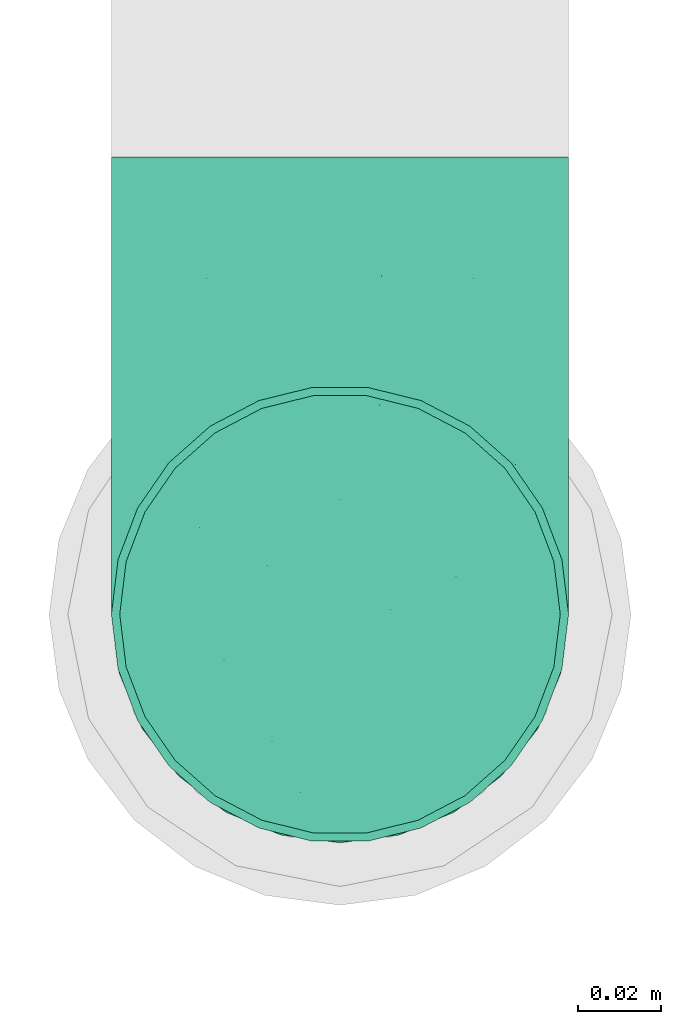
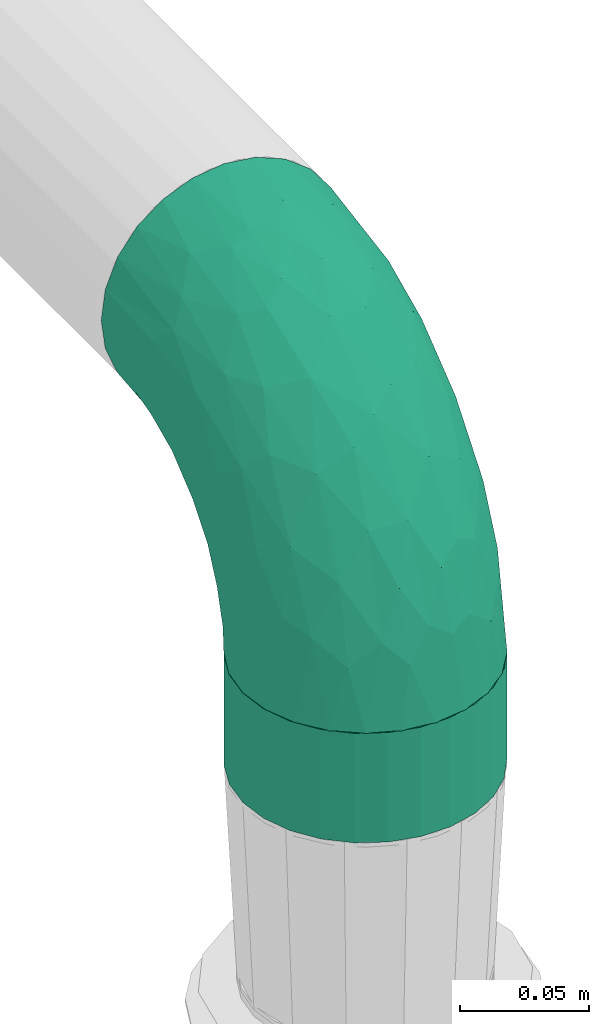
# One storey, part 79 of 115: 1 flow fitting, 1 flow segment.
"""IFC2X3 building model written with IfcOpenShell, lengths in millimetres."""

from ifc_helpers import new_model, entity, si_unit, converted_unit, derived_unit, direction, frame, origin_with_axes, origin_2d_with_axis, place, context, subcontext, project, spatial, hollow_circle, extrude, open_shell, surface_model, source, transform, mapped, material, layer, layer_set, layer_usage, type_object, element, save


model = new_model("IFC2X3")

# Units and contexts
model_context = context("Model", 3, precision=1e-05, world=origin_with_axes(), true_north=direction((0.0, 1.0)))
body_context = subcontext(model_context, "Body", "Model", "MODEL_VIEW")
ifc_project = project(units=[si_unit("AREAUNIT", "SQUARE_METRE"), si_unit("VOLUMEUNIT", "CUBIC_METRE", prefix="DECI"), si_unit("TIMEUNIT", "SECOND"), si_unit("THERMODYNAMICTEMPERATUREUNIT", "DEGREE_CELSIUS"), si_unit("PRESSUREUNIT", "PASCAL"), si_unit("MASSUNIT", "GRAM", prefix="KILO"), si_unit("LENGTHUNIT", "METRE", prefix="MILLI"), si_unit("POWERUNIT", "WATT"), si_unit("ELECTRICCURRENTUNIT", "AMPERE"), si_unit("ELECTRICVOLTAGEUNIT", "VOLT"), derived_unit("VOLUMETRICFLOWRATEUNIT", [(si_unit("VOLUMEUNIT", "CUBIC_METRE", prefix="DECI"), 1), (si_unit("TIMEUNIT", "SECOND"), -1)]), derived_unit("LINEARVELOCITYUNIT", [(si_unit("LENGTHUNIT", "METRE"), 1), (si_unit("TIMEUNIT", "SECOND"), -1)]), derived_unit("MASSDENSITYUNIT", [(si_unit("MASSUNIT", "GRAM", prefix="KILO"), 1), (si_unit("VOLUMEUNIT", "CUBIC_METRE"), -1)]), converted_unit("PLANEANGLEUNIT", "DEGREE", entity("IfcRatioMeasure", 0.01745), si_unit("PLANEANGLEUNIT", "RADIAN"), dimensions=[0, 0, 0, 0, 0, 0, 0])], contexts=[model_context])

# Site, building, storey
site_placement = place(None, origin_with_axes())
site = spatial("IfcSite", under=ifc_project, at=site_placement, CompositionType="ELEMENT")
building_placement = place(site_placement, origin_with_axes())
building = spatial("IfcBuilding", under=site, at=building_placement, Name="mc-building", CompositionType="ELEMENT")
storey_placement = place(building_placement, frame((0.0, 0.0, 2950.0), z_axis=(0.0, 0.0, 1.0), x_axis=(1.0, 0.0, 0.0)))
storey = spatial("IfcBuildingStorey", under=building, at=storey_placement, Name="2. Korrus", CompositionType="ELEMENT", Elevation=2950.0)

# Flow segment
ifc_material = material(Name="FZ1")
ifc_layer = layer(ifc_material, 0.0)
ifc_layer_set = layer_set([ifc_layer], Name="FZ1")
ifc_layer_usage = layer_usage(ifc_layer_set, "AXIS1", "POSITIVE", 0.0)
duct_segment_type = type_object("IfcDuctSegmentType", PredefinedType="RIGIDSEGMENT")
shared_shape_1 = source(origin_with_axes(), body_context, "Body", "SweptSolid", [
    extrude(hollow_circle(Radius=55.0, WallThickness=2.0, at=origin_2d_with_axis()), frame((0.0, 0.0, 0.0), z_axis=(1.0, 0.0, 0.0), x_axis=(0.0, 1.0, 0.0)), (0.0, 0.0, 1.0), 51.9),
])
flow_segment_placement = place(storey_placement, frame((18604.54349, 8183.57591, 2355.0), z_axis=(0.0, 1.0, 0.0), x_axis=(0.0, 0.0, -1.0)))
element("IfcFlowSegment", 1, at=flow_segment_placement, inside=storey, type_object=duct_segment_type, material=ifc_layer_usage, context=body_context, shape_type="MappedRepresentation", body=[
    mapped(shared_shape_1, transform((0.0, 0.0, 0.0), scale=1.0)),
])

# Flow fitting
duct_fitting_type = type_object("IfcDuctFittingType", Name="BU", PredefinedType="BEND")
shared_shape_2 = source(origin_with_axes(), body_context, "Body", "SurfaceModel", [
    surface_model("IfcShellBasedSurfaceModel", [(-110.0, -38.89087, -38.89087), (-110.0, -55.0, 0.0), (-110.0, -27.5, -47.63139), (-110.0, -53.12592, -14.23505), (-110.0, -47.63139, -27.5), (-110.0, 47.63139, -27.5), (-110.0, 53.12592, 14.23505), (-110.0, 53.12592, -14.23505), (-110.0, -14.23505, -53.12592), (-110.0, 0.0, -55.0), (-110.0, 38.89087, -38.89087), (-110.0, 27.5, -47.63139), (-110.0, 14.23505, -53.12592), (-110.0, 55.0, 0.0), (-110.0, -53.12592, 14.23505), (-110.0, -47.63139, 27.5), (-110.0, -38.89087, 38.89087), (-110.0, 0.0, 55.0), (-110.0, -27.5, 47.63139), (-110.0, -14.23505, 53.12592), (-110.0, 38.89087, 38.89087), (-110.0, 47.63139, 27.5), (-110.0, 27.5, 47.63139), (-110.0, 14.23505, 53.12592), (0.0, -110.0, -55.0), (14.23505, -110.0, -53.12592), (-14.23505, -110.0, -53.12592), (-53.12592, -110.0, 14.23505), (-27.5, -110.0, -47.63139), (-47.63139, -110.0, -27.5), (-38.89087, -110.0, -38.89087), (55.0, -110.0, 0.0), (53.12592, -110.0, 14.23505), (38.89087, -110.0, -38.89087), (27.5, -110.0, -47.63139), (53.12592, -110.0, -14.23505), (47.63139, -110.0, -27.5), (-53.12592, -110.0, -14.23505), (-47.63139, -110.0, 27.5), (-38.89087, -110.0, 38.89087), (14.23505, -110.0, 53.12592), (-27.5, -110.0, 47.63139), (-14.23505, -110.0, 53.12592), (47.63139, -110.0, 27.5), (38.89087, -110.0, 38.89087), (27.5, -110.0, 47.63139), (0.0, -110.0, 55.0), (-55.0, -110.0, 0.0), (-60.44912, -32.56953, 51.94617), (-76.6405, -38.18013, 45.55988), (-64.21732, -48.68956, 43.63444), (-90.15553, -11.94394, 54.09138), (-76.00813, -5.38378, 55.0), (-70.18771, -18.55163, 54.03432), (-78.5998, -26.77405, 50.81338), (-93.27622, -45.77614, 33.48188), (-75.55424, -54.2118, 32.41257), (-96.12334, -22.13664, 50.81337), (-32.04182, -59.64019, 52.24446), (-18.36258, -70.48427, 54.04484), (-21.00813, -45.34362, 55.0), (-63.60674, -66.07878, 29.97482), (-74.66383, -63.08407, 19.92123), (-63.88653, -74.77858, 17.99134), (-93.11138, -56.59448, 10.50359), (-99.597, -52.72185, 18.52927), (-98.21577, -57.34403, 0.0), (-53.42855, -92.60092, 21.04759), (-88.54852, -54.8376, 21.04759), (-5.38378, -76.00813, 55.0), (-11.86161, -90.23965, 54.10313), (-56.64619, -93.12774, 10.22088), (-57.34403, -98.21577, 0.0), (-44.60838, -44.60838, 52.13415), (-45.34362, -21.00813, 55.0), (-92.68484, -35.46673, 43.63443), (-22.25266, -95.40765, 50.81337), (-27.23711, -77.39884, 50.81337), (-43.70931, -69.58671, 44.47149), (-35.97783, -90.61597, 43.63443), (-58.67786, -84.31125, 16.04456), (-57.2828, -79.3123, 24.9774), (-82.93277, -60.36161, 12.91784), (-49.88337, -54.51816, 47.224), (-74.57753, -66.83759, 9.55742), (-45.35812, -94.97281, 33.48188), (-59.18663, -88.95241, 0.0), (-51.517, -78.6292, 33.48188), (-65.14788, -80.03077, 0.0), (-56.45322, -62.06476, 39.63545), (-88.95241, -59.18663, 0.0), (-80.03077, -65.14788, 0.0), (-71.10913, -71.10913, 0.0), (-94.9309, -45.36788, -33.48188), (-93.11358, -56.60141, -10.46614), (-99.64997, -52.79499, -18.30015), (-79.99933, -46.56772, -37.92748), (-90.20425, -36.08686, -43.63443), (-45.34362, -21.00813, -55.0), (-72.75364, -19.68651, -53.60527), (-76.00813, -5.38378, -55.0), (-21.00813, -45.34362, -55.0), (-5.38378, -76.00813, -55.0), (-21.91957, -65.12078, -53.85897), (-35.41876, -92.89265, -43.63443), (-91.10309, -11.02766, -54.21832), (-45.77614, -93.27622, -33.48188), (-90.50474, -23.21022, -50.81337), (-70.92854, -33.31794, -49.51754), (-78.52933, -63.35627, -11.73997), (-24.91508, -84.05606, -50.81337), (-88.78941, -54.74452, -21.04759), (-63.49062, -67.59111, -28.46929), (-73.36422, -62.46673, -22.94182), (-69.59921, -57.34866, -33.48187), (-56.59448, -93.11138, -10.50359), (-54.10679, -75.85581, -32.31867), (-54.8376, -88.54852, -21.04759), (-57.75956, -31.09612, -52.80882), (-52.72185, -99.597, -18.52927), (-12.62913, -89.46304, -53.99097), (-34.46825, -66.46123, -50.04329), (-43.9837, -43.9837, -52.42279), (-65.78527, -72.58348, -17.68796), (-57.47001, -51.99467, -44.91465), (-70.34468, -43.65295, -44.21951), (-60.72547, -82.29174, -12.88567), (-42.34915, -74.24548, -43.63444), (-57.25194, -63.5016, -38.08211), (-80.95344, -53.56991, -29.32027), (-52.32891, -4.55257, -54.0482), (14.95561, -36.05775, -42.26543), (14.88266, -20.92917, -33.7947), (32.52942, -47.13398, -30.48571), (19.3559, -65.35825, -48.00507), (30.24048, -70.09027, -41.7461), (-28.49299, 30.5778, -16.4009), (-47.13398, 32.52942, -30.48571), (-70.35075, 46.44478, -19.5952), (-22.4954, -22.4954, -53.25347), (-4.55257, -52.32891, -54.0482), (-75.47368, 11.22546, -52.60718), (-81.32209, 51.5606, -9.98467), (-70.09027, 30.24048, -41.7461), (-80.81763, 41.84862, -32.14655), (-9.15831, 10.852, -27.8997), (-36.05774, 14.95561, -42.26543), (-65.35825, 19.3559, -48.00507), (3.94376, -43.9333, -50.53315), (11.22546, -75.47368, -52.60718), (-43.9333, 3.94376, -50.53315), (-13.39742, -13.39743, -48.13058), (50.20582, -74.51695, -9.9731), (41.8609, -47.82256, -9.92641), (49.37776, -67.29486, 0.0), (18.93131, -11.7156, -17.56239), (-1.23348, 12.25375, -12.18106), (-27.5, 32.89419, 0.0), (41.84862, -80.81763, -32.14655), (46.44478, -70.35075, -19.5952), (35.70604, -41.31408, -20.38235), (6.67262, 6.67262, 0.0), (32.89419, -27.5, 0.0), (-50.36265, 42.95545, -9.51562), (-67.29486, 49.37776, 0.0), (-5.47251, -5.47251, -39.92906), (-70.35075, 46.44478, 19.5952), (-74.51695, 50.20582, 9.9731), (-47.13398, 32.52942, 30.48571), (-41.31407, 35.70604, 20.38235), (-80.81763, 41.84862, 32.14655), (11.22546, -75.47368, 52.60718), (-4.55257, -52.32891, 54.0482), (-36.05774, 14.95561, 42.26543), (-65.35825, 19.3559, 48.00507), (-43.9333, 3.94376, 50.53315), (-70.09027, 30.24048, 41.7461), (-11.7156, 18.93131, 17.56239), (12.25375, -1.23348, 12.18106), (30.5778, -28.49299, 16.4009), (42.95545, -50.36265, 9.51562), (51.5606, -81.32209, 9.98467), (-52.32891, -4.55257, 54.0482), (-75.47368, 11.22546, 52.60718), (-13.39742, -13.39743, 48.13058), (-22.4954, -22.4954, 53.25347), (3.94376, -43.9333, 50.53315), (-20.92916, 14.88266, 33.79469), (10.852, -9.15831, 27.8997), (-47.82256, 41.8609, 9.92641), (32.52942, -47.13398, 30.48571), (46.44478, -70.35075, 19.5952), (41.84862, -80.81763, 32.14655), (14.95561, -36.05775, 42.26543), (19.3559, -65.35825, 48.00507), (30.24048, -70.09027, 41.7461), (-5.47251, -5.47251, 39.92906)], [open_shell([[[0, 1, 2]], [[3, 1, 4]], [[5, 6, 7]], [[8, 1, 9]], [[2, 1, 8]], [[4, 1, 0]], [[10, 9, 6]], [[9, 10, 11]], [[11, 12, 9]], [[6, 5, 10]], [[7, 6, 13]], [[14, 15, 9]], [[9, 15, 16]], [[17, 16, 18]], [[9, 16, 17]], [[19, 17, 18]], [[9, 20, 21]], [[6, 9, 21]], [[9, 22, 20]], [[23, 22, 9]], [[17, 23, 9]], [[9, 1, 14]], [[24, 25, 26]], [[26, 27, 28]], [[29, 30, 27]], [[28, 27, 30]], [[26, 31, 32]], [[33, 31, 34]], [[25, 34, 31]], [[35, 31, 36]], [[33, 36, 31]], [[31, 26, 25]], [[29, 27, 37]], [[38, 27, 26]], [[39, 38, 26]], [[40, 41, 26]], [[41, 39, 26]], [[40, 42, 41]], [[43, 44, 26]], [[43, 26, 32]], [[44, 45, 26]], [[26, 45, 40]], [[40, 46, 42]], [[47, 37, 27]], [[48, 49, 50]], [[51, 52, 17]], [[48, 53, 54]], [[49, 55, 56]], [[16, 15, 55]], [[18, 57, 19]], [[58, 59, 60]], [[61, 62, 63]], [[64, 65, 14]], [[53, 51, 54]], [[66, 64, 14]], [[27, 38, 67]], [[65, 68, 55]], [[68, 65, 64]], [[69, 59, 70]], [[71, 72, 27]], [[73, 60, 74]], [[55, 49, 75]], [[42, 70, 76]], [[51, 57, 54]], [[77, 78, 79]], [[42, 76, 41]], [[46, 70, 42]], [[55, 68, 56]], [[75, 18, 16]], [[77, 79, 76]], [[80, 67, 81]], [[68, 82, 62]], [[83, 78, 58]], [[82, 84, 62]], [[39, 79, 85]], [[71, 67, 80]], [[72, 71, 86]], [[67, 85, 87]], [[88, 80, 63]], [[39, 41, 79]], [[87, 79, 78]], [[55, 75, 16]], [[50, 89, 83]], [[38, 39, 85]], [[56, 68, 62]], [[61, 87, 89]], [[48, 50, 83]], [[18, 75, 57]], [[54, 75, 49]], [[38, 85, 67]], [[85, 79, 87]], [[56, 62, 61]], [[50, 56, 89]], [[87, 61, 81]], [[90, 64, 66]], [[14, 1, 66]], [[91, 92, 84]], [[82, 90, 91]], [[90, 82, 64]], [[62, 84, 63]], [[84, 82, 91]], [[64, 82, 68]], [[65, 15, 14]], [[15, 65, 55]], [[72, 47, 27]], [[86, 71, 80]], [[67, 71, 27]], [[88, 63, 92]], [[63, 80, 81]], [[63, 81, 61]], [[87, 81, 67]], [[41, 76, 79]], [[70, 59, 77]], [[76, 70, 77]], [[69, 70, 46]], [[77, 59, 58]], [[59, 69, 60]], [[77, 58, 78]], [[73, 58, 60]], [[19, 57, 51]], [[54, 57, 75]], [[19, 51, 17]], [[53, 52, 51]], [[53, 74, 52]], [[73, 74, 48]], [[53, 48, 74]], [[83, 73, 48]], [[73, 83, 58]], [[78, 83, 89]], [[78, 89, 87]], [[61, 89, 56]], [[54, 49, 48]], [[50, 49, 56]], [[88, 86, 80]], [[63, 84, 92]], [[93, 4, 0]], [[66, 94, 90]], [[95, 94, 3]], [[96, 93, 97]], [[98, 99, 100]], [[0, 2, 97]], [[101, 102, 103]], [[104, 28, 30]], [[9, 105, 8]], [[30, 106, 104]], [[107, 105, 99]], [[97, 107, 108]], [[94, 109, 90]], [[2, 8, 107]], [[94, 66, 3]], [[110, 26, 28]], [[94, 111, 109]], [[112, 113, 114]], [[72, 115, 37]], [[116, 106, 117]], [[98, 118, 99]], [[119, 115, 117]], [[115, 119, 37]], [[110, 120, 26]], [[103, 110, 121]], [[117, 106, 119]], [[120, 110, 103]], [[98, 101, 122]], [[117, 123, 116]], [[108, 124, 125]], [[126, 117, 115]], [[30, 29, 106]], [[120, 102, 24]], [[110, 104, 127]], [[97, 125, 96]], [[118, 122, 124]], [[124, 127, 128]], [[93, 0, 97]], [[86, 126, 115]], [[127, 106, 116]], [[129, 113, 111]], [[4, 93, 95]], [[114, 129, 96]], [[28, 104, 110]], [[127, 104, 106]], [[2, 107, 97]], [[108, 107, 99]], [[118, 108, 99]], [[100, 99, 105]], [[128, 112, 114]], [[127, 124, 121]], [[66, 1, 3]], [[91, 90, 109]], [[95, 111, 94]], [[109, 123, 92]], [[114, 113, 129]], [[111, 95, 93]], [[95, 3, 4]], [[86, 115, 72]], [[37, 47, 72]], [[88, 92, 123]], [[123, 117, 126]], [[126, 88, 123]], [[88, 126, 86]], [[119, 29, 37]], [[29, 119, 106]], [[111, 93, 129]], [[124, 114, 125]], [[100, 105, 9]], [[8, 105, 107]], [[108, 118, 124]], [[122, 118, 98]], [[96, 129, 93]], [[109, 111, 113]], [[113, 123, 109]], [[116, 123, 112]], [[113, 112, 123]], [[116, 112, 128]], [[116, 128, 127]], [[124, 128, 114]], [[103, 122, 101]], [[127, 121, 110]], [[121, 122, 103]], [[122, 121, 124]], [[26, 120, 24]], [[102, 120, 103]], [[108, 125, 97]], [[109, 92, 91]], [[96, 125, 114]], [[100, 130, 98]], [[131, 132, 133]], [[134, 135, 34]], [[136, 137, 138]], [[101, 139, 140]], [[9, 141, 100]], [[138, 7, 142]], [[137, 143, 144]], [[142, 7, 13]], [[145, 146, 137]], [[146, 147, 143]], [[5, 138, 144]], [[7, 138, 5]], [[5, 144, 10]], [[140, 148, 149]], [[143, 11, 10]], [[147, 12, 11]], [[100, 141, 130]], [[98, 139, 101]], [[148, 134, 149]], [[139, 150, 151]], [[152, 153, 154]], [[150, 139, 130]], [[25, 24, 149]], [[141, 12, 147]], [[132, 145, 155]], [[156, 136, 157]], [[158, 33, 135]], [[148, 139, 151]], [[36, 33, 158]], [[34, 135, 33]], [[159, 160, 153]], [[160, 159, 133]], [[137, 146, 143]], [[152, 154, 31]], [[137, 136, 145]], [[161, 162, 155]], [[133, 159, 158]], [[134, 148, 131]], [[163, 164, 157]], [[163, 142, 164]], [[102, 101, 140]], [[162, 154, 153]], [[159, 35, 36]], [[155, 156, 161]], [[131, 165, 132]], [[155, 145, 156]], [[98, 130, 139]], [[150, 130, 141]], [[147, 150, 141]], [[9, 12, 141]], [[149, 24, 102]], [[148, 140, 139]], [[140, 149, 102]], [[34, 25, 134]], [[146, 151, 150]], [[143, 147, 11]], [[147, 146, 150]], [[145, 165, 146]], [[25, 149, 134]], [[135, 134, 131]], [[135, 131, 133]], [[151, 165, 131]], [[148, 151, 131]], [[165, 151, 146]], [[160, 133, 132]], [[132, 165, 145]], [[36, 158, 159]], [[133, 158, 135]], [[10, 144, 143]], [[137, 144, 138]], [[162, 153, 155]], [[159, 153, 152]], [[160, 155, 153]], [[155, 160, 132]], [[152, 35, 159]], [[35, 152, 31]], [[136, 138, 163]], [[164, 142, 13]], [[142, 163, 138]], [[136, 163, 157]], [[161, 156, 157]], [[136, 156, 145]], [[166, 6, 21]], [[167, 164, 13]], [[166, 168, 169]], [[170, 168, 166]], [[69, 171, 172]], [[173, 174, 175]], [[174, 176, 22]], [[161, 157, 177]], [[170, 20, 176]], [[21, 20, 170]], [[178, 179, 162]], [[180, 181, 154]], [[182, 175, 183]], [[183, 23, 17]], [[184, 185, 186]], [[74, 185, 182]], [[52, 74, 182]], [[187, 188, 177]], [[166, 169, 189]], [[190, 179, 188]], [[22, 176, 20]], [[180, 154, 162]], [[32, 191, 43]], [[192, 44, 43]], [[43, 191, 192]], [[32, 31, 181]], [[193, 194, 195]], [[194, 40, 45]], [[190, 193, 195]], [[45, 44, 195]], [[69, 46, 171]], [[74, 60, 185]], [[157, 164, 189]], [[167, 189, 164]], [[172, 60, 69]], [[185, 172, 186]], [[173, 187, 168]], [[191, 32, 181]], [[190, 195, 192]], [[179, 190, 191]], [[175, 174, 183]], [[171, 40, 194]], [[188, 193, 190]], [[175, 185, 184]], [[177, 178, 161]], [[173, 196, 187]], [[177, 188, 178]], [[60, 172, 185]], [[186, 172, 171]], [[194, 186, 171]], [[46, 40, 171]], [[183, 17, 52]], [[175, 182, 185]], [[182, 183, 52]], [[22, 23, 174]], [[193, 184, 186]], [[195, 194, 45]], [[194, 193, 186]], [[188, 196, 193]], [[23, 183, 174]], [[176, 174, 173]], [[176, 173, 168]], [[184, 196, 173]], [[175, 184, 173]], [[196, 184, 193]], [[169, 168, 187]], [[187, 196, 188]], [[21, 170, 166]], [[168, 170, 176]], [[44, 192, 195]], [[190, 192, 191]], [[157, 189, 177]], [[166, 189, 167]], [[169, 177, 189]], [[177, 169, 187]], [[167, 6, 166]], [[6, 167, 13]], [[179, 191, 180]], [[154, 181, 31]], [[181, 180, 191]], [[179, 180, 162]], [[161, 178, 162]], [[179, 178, 188]]])]),
])
flow_fitting_placement = place(storey_placement, frame((18604.54349, 8183.57591, 2465.0), z_axis=(-1.0, 0.0, 0.0), x_axis=(0.0, -1.0, 0.0)))
element("IfcFlowFitting", 2, at=flow_fitting_placement, inside=storey, type_object=duct_fitting_type, Name="BU", context=body_context, shape_type="MappedRepresentation", body=[
    mapped(shared_shape_2, transform((0.0, 0.0, 0.0), scale=1.0)),
])

save(model, "model.ifc")
